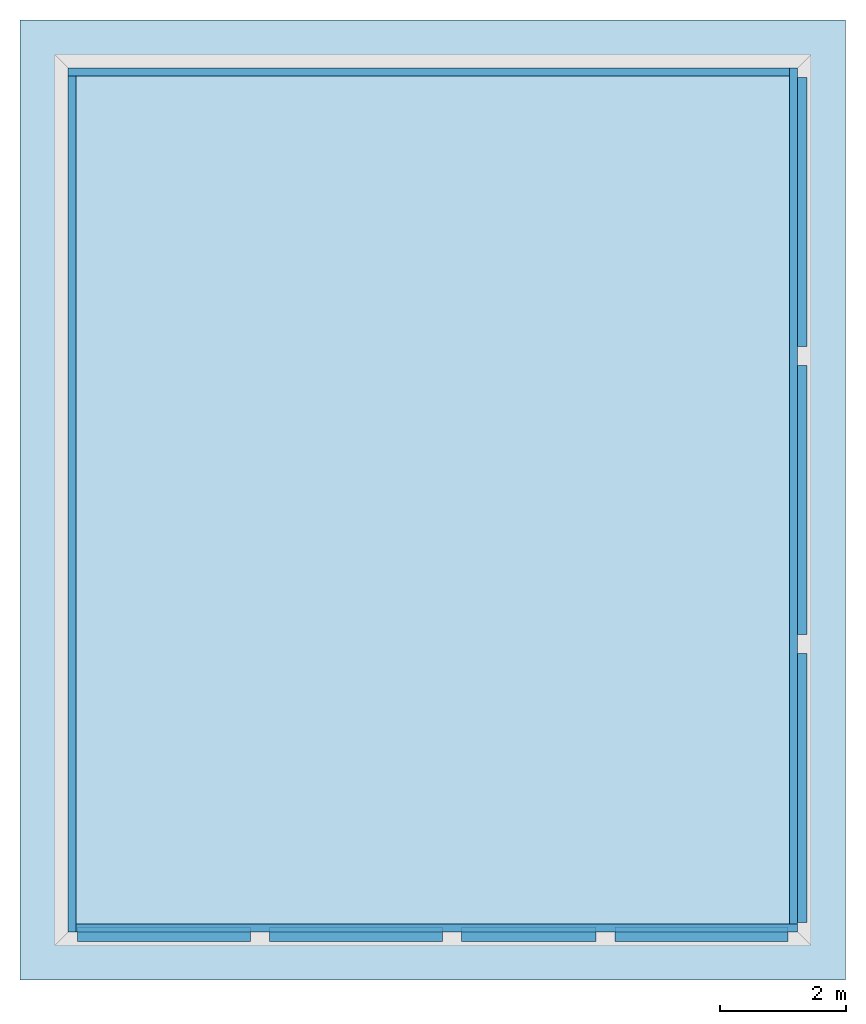
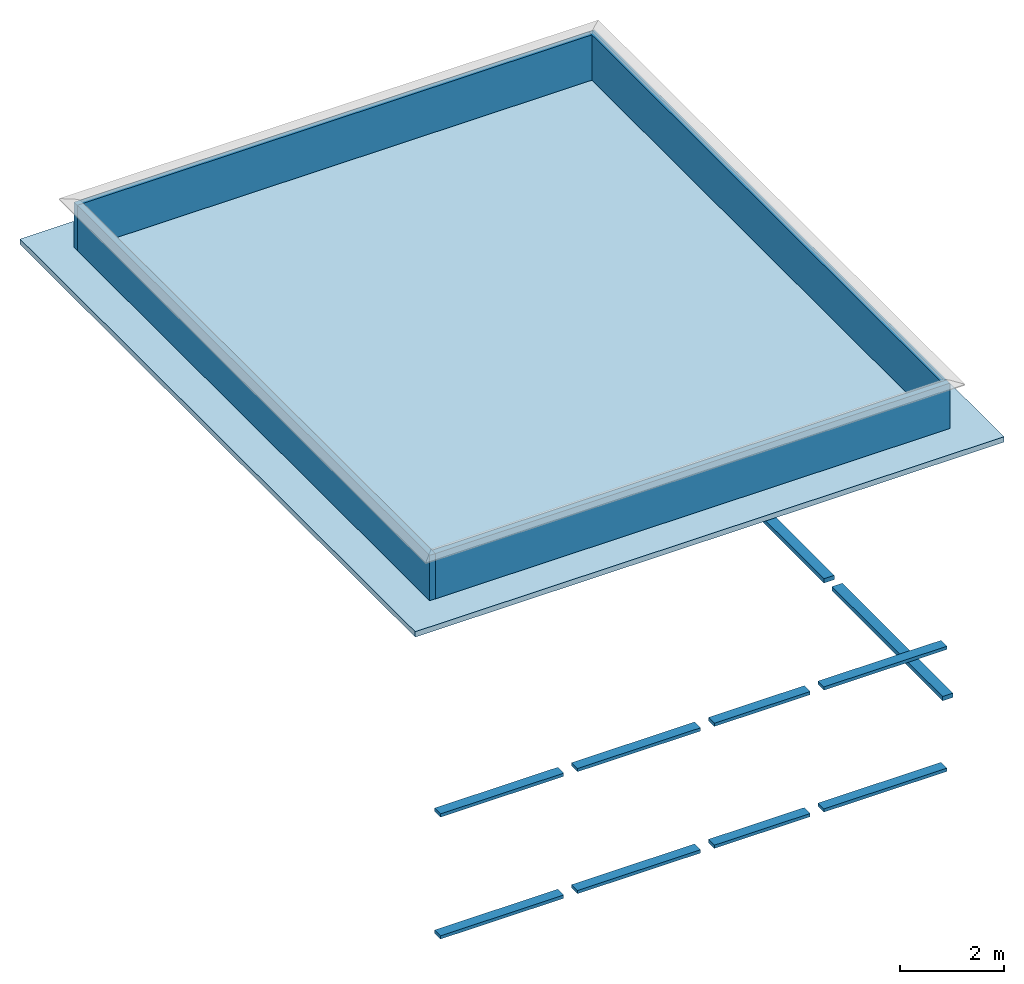
# One storey, part 1 of 2: 4 walls, 3 beams, 1 slab.
"""IFC2X3 building model written with IfcOpenShell, lengths in feet."""

from ifc_helpers import new_model, entity, si_unit, converted_unit, derived_unit, direction, frame, frame_2d, origin, origin_2d_with_axis, place, context, subcontext, project, spatial, rectangle, extrude, source, transform, mapped, material, layer, layer_set, layer_usage, type_object, type_shapes, element, save


model = new_model("IFC2X3")

# Units and contexts
model_context = context("Model", 3, precision=0.0001, world=origin(), true_north=direction((6.123031769111886e-17, 1.0)))
body_context = subcontext(model_context, "Body", "Model", "MODEL_VIEW")
ifc_project = project(units=[converted_unit("LENGTHUNIT", "FOOT", entity("IfcLengthMeasure", 0.3048), si_unit("LENGTHUNIT", "METRE"), dimensions=[1, 0, 0, 0, 0, 0, 0]), converted_unit("AREAUNIT", "SQUARE FOOT", entity("IfcAreaMeasure", 0.09290304), si_unit("AREAUNIT", "SQUARE_METRE"), dimensions=[2, 0, 0, 0, 0, 0, 0]), converted_unit("VOLUMEUNIT", "CUBIC FOOT", entity("IfcVolumeMeasure", 0.028316846592000004), si_unit("VOLUMEUNIT", "CUBIC_METRE"), dimensions=[3, 0, 0, 0, 0, 0, 0]), converted_unit("PLANEANGLEUNIT", "DEGREE", entity("IfcPlaneAngleMeasure", 0.017453292519943278), si_unit("PLANEANGLEUNIT", "RADIAN"), dimensions=[0, 0, 0, 0, 0, 0, 0]), si_unit("MASSUNIT", "GRAM", prefix="KILO"), derived_unit("MASSDENSITYUNIT", [(si_unit("MASSUNIT", "GRAM", prefix="KILO"), 1), (si_unit("LENGTHUNIT", "METRE"), -3)]), derived_unit("IONCONCENTRATIONUNIT", [(si_unit("MASSUNIT", "GRAM", prefix="KILO"), 1), (si_unit("LENGTHUNIT", "METRE"), -3)]), derived_unit("MOMENTOFINERTIAUNIT", [(si_unit("LENGTHUNIT", "METRE"), 4)]), si_unit("TIMEUNIT", "SECOND"), si_unit("FREQUENCYUNIT", "HERTZ"), si_unit("THERMODYNAMICTEMPERATUREUNIT", "DEGREE_CELSIUS"), derived_unit("THERMALTRANSMITTANCEUNIT", [(si_unit("MASSUNIT", "GRAM", prefix="KILO"), 1), (si_unit("THERMODYNAMICTEMPERATUREUNIT", "KELVIN"), -1), (si_unit("TIMEUNIT", "SECOND"), -3)]), derived_unit("THERMALCONDUCTANCEUNIT", [(si_unit("MASSUNIT", "GRAM", prefix="KILO"), 1), (si_unit("THERMODYNAMICTEMPERATUREUNIT", "KELVIN"), -1), (si_unit("TIMEUNIT", "SECOND"), -3), (si_unit("LENGTHUNIT", "METRE"), 1)]), derived_unit("VOLUMETRICFLOWRATEUNIT", [(si_unit("LENGTHUNIT", "METRE"), 3), (si_unit("TIMEUNIT", "SECOND"), -1)]), derived_unit("MASSFLOWRATEUNIT", [(si_unit("MASSUNIT", "GRAM", prefix="KILO"), 1), (si_unit("TIMEUNIT", "SECOND"), -1)]), derived_unit("ROTATIONALFREQUENCYUNIT", [(si_unit("TIMEUNIT", "SECOND"), -1)]), si_unit("ELECTRICCURRENTUNIT", "AMPERE"), si_unit("ELECTRICVOLTAGEUNIT", "VOLT"), si_unit("POWERUNIT", "WATT"), converted_unit("FORCEUNIT", "KIP", entity("IfcForceMeasure", 2.088543423315013e-05), si_unit("FORCEUNIT", "NEWTON"), dimensions=[1, 1, -2, 0, 0, 0, 0]), si_unit("ILLUMINANCEUNIT", "LUX"), si_unit("LUMINOUSFLUXUNIT", "LUMEN"), si_unit("LUMINOUSINTENSITYUNIT", "CANDELA"), si_unit("ENERGYUNIT", "JOULE"), derived_unit("USERDEFINED", [(si_unit("MASSUNIT", "GRAM", prefix="KILO"), -1), (si_unit("LENGTHUNIT", "METRE"), -2), (si_unit("TIMEUNIT", "SECOND"), 3), (si_unit("LUMINOUSFLUXUNIT", "LUMEN"), 1)]), derived_unit("USERDEFINED", [(si_unit("MASSUNIT", "GRAM", prefix="KILO"), 1), (si_unit("TIMEUNIT", "SECOND"), -3), (si_unit("LENGTHUNIT", "METRE"), 3), (si_unit("ELECTRICCURRENTUNIT", "AMPERE"), -2)]), derived_unit("SOUNDPOWERUNIT", [(si_unit("MASSUNIT", "GRAM", prefix="KILO"), 1), (si_unit("TIMEUNIT", "SECOND"), -3), (si_unit("LENGTHUNIT", "METRE"), 2)]), derived_unit("SOUNDPRESSUREUNIT", [(si_unit("MASSUNIT", "GRAM", prefix="KILO"), 1), (si_unit("LENGTHUNIT", "METRE"), -1), (si_unit("TIMEUNIT", "SECOND"), -2)]), derived_unit("LINEARVELOCITYUNIT", [(si_unit("LENGTHUNIT", "METRE"), 1), (si_unit("TIMEUNIT", "SECOND"), -1)]), si_unit("PRESSUREUNIT", "PASCAL"), derived_unit("USERDEFINED", [(si_unit("MASSUNIT", "GRAM", prefix="KILO"), 1), (si_unit("LENGTHUNIT", "METRE"), -2), (si_unit("TIMEUNIT", "SECOND"), -2)]), derived_unit("LINEARFORCEUNIT", [(si_unit("MASSUNIT", "GRAM", prefix="KILO"), 1), (si_unit("TIMEUNIT", "SECOND"), -2)]), derived_unit("PLANARFORCEUNIT", [(si_unit("MASSUNIT", "GRAM", prefix="KILO"), 1), (si_unit("LENGTHUNIT", "METRE"), -1), (si_unit("TIMEUNIT", "SECOND"), -2)]), derived_unit("SPECIFICHEATCAPACITYUNIT", [(si_unit("THERMODYNAMICTEMPERATUREUNIT", "KELVIN"), -1), (si_unit("LENGTHUNIT", "METRE"), 2), (si_unit("TIMEUNIT", "SECOND"), -2)]), derived_unit("HEATFLUXDENSITYUNIT", [(si_unit("MASSUNIT", "GRAM", prefix="KILO"), 1), (si_unit("TIMEUNIT", "SECOND"), -3)]), derived_unit("HEATINGVALUEUNIT", [(si_unit("LENGTHUNIT", "METRE"), 2), (si_unit("TIMEUNIT", "SECOND"), -2)]), derived_unit("VAPORPERMEABILITYUNIT", [(si_unit("LENGTHUNIT", "METRE"), -1), (si_unit("TIMEUNIT", "SECOND"), 1)]), derived_unit("DYNAMICVISCOSITYUNIT", [(si_unit("MASSUNIT", "GRAM", prefix="KILO"), 1), (si_unit("TIMEUNIT", "SECOND"), -1), (si_unit("LENGTHUNIT", "METRE"), -1)]), derived_unit("THERMALEXPANSIONCOEFFICIENTUNIT", [(si_unit("THERMODYNAMICTEMPERATUREUNIT", "KELVIN"), -1)]), derived_unit("MODULUSOFELASTICITYUNIT", [(si_unit("MASSUNIT", "GRAM", prefix="KILO"), 1), (si_unit("LENGTHUNIT", "METRE"), -1), (si_unit("TIMEUNIT", "SECOND"), -2)]), derived_unit("ISOTHERMALMOISTURECAPACITYUNIT", [(si_unit("LENGTHUNIT", "METRE"), 3), (si_unit("MASSUNIT", "GRAM", prefix="KILO"), -1)]), derived_unit("MOISTUREDIFFUSIVITYUNIT", [(si_unit("TIMEUNIT", "SECOND"), -1), (si_unit("LENGTHUNIT", "METRE"), 2)]), derived_unit("MASSPERLENGTHUNIT", [(si_unit("MASSUNIT", "GRAM", prefix="KILO"), 1), (si_unit("LENGTHUNIT", "METRE"), -1)]), derived_unit("THERMALRESISTANCEUNIT", [(si_unit("MASSUNIT", "GRAM", prefix="KILO"), -1), (si_unit("TIMEUNIT", "SECOND"), 3), (si_unit("THERMODYNAMICTEMPERATUREUNIT", "KELVIN"), 1)]), derived_unit("ACCELERATIONUNIT", [(si_unit("LENGTHUNIT", "METRE"), 1), (si_unit("TIMEUNIT", "SECOND"), -2)]), derived_unit("ANGULARVELOCITYUNIT", [(si_unit("TIMEUNIT", "SECOND"), -1), (si_unit("PLANEANGLEUNIT", "RADIAN"), 1)]), derived_unit("LINEARSTIFFNESSUNIT", [(si_unit("MASSUNIT", "GRAM", prefix="KILO"), 1), (si_unit("TIMEUNIT", "SECOND"), -2)]), derived_unit("WARPINGCONSTANTUNIT", [(si_unit("LENGTHUNIT", "METRE"), 6)]), derived_unit("LINEARMOMENTUNIT", [(si_unit("MASSUNIT", "GRAM", prefix="KILO"), 1), (si_unit("LENGTHUNIT", "METRE"), 1), (si_unit("TIMEUNIT", "SECOND"), -2)]), derived_unit("TORQUEUNIT", [(si_unit("MASSUNIT", "GRAM", prefix="KILO"), 1), (si_unit("LENGTHUNIT", "METRE"), 2), (si_unit("TIMEUNIT", "SECOND"), -2)])], contexts=[model_context])

# Site, building, storey
site_placement = place(None, origin())
site = spatial("IfcSite", under=ifc_project, at=site_placement, CompositionType="ELEMENT")
building_placement = place(site_placement, origin())
building = spatial("IfcBuilding", under=site, at=building_placement, CompositionType="ELEMENT")
storey_placement = place(building_placement, frame((0.0, 0.0, 28.25000000000186)))
storey = spatial("IfcBuildingStorey", under=building, at=storey_placement, Name="Third Floor", CompositionType="ELEMENT", Elevation=28.25000000000186)

# Beams
ifc_material_1 = material(Name="Concrete, Cast-in-Place gray")
beam_type_1 = type_object("IfcBeamType", PredefinedType="BEAM", material=ifc_material_1)
shared_shape_1 = source(origin(), body_context, "Body", "SweptSolid", [
    extrude(rectangle(XDim=0.33333333333333304, YDim=0.7500000000000142, at=frame_2d((-7.105427357601002e-15, -4.440892098500626e-16), x_axis=(0.0, 1.0))), frame((47.999478019162154, -19.341244847249058, 7.166666666666661), z_axis=(0.0, 1.0, 0.0), x_axis=(-1.0, 0.0, 0.0)), (0.0, 0.0, 1.0), 14.000000000000057),
    extrude(rectangle(XDim=0.33333333333333304, YDim=0.7500000000000142, at=frame_2d((-7.105427357601002e-15, -4.440892098500626e-16), x_axis=(0.0, 1.0))), frame((47.999478019162154, -49.34124484724906, 7.166666666666661), z_axis=(0.0, 1.0, 0.0), x_axis=(-1.0, 0.0, 0.0)), (0.0, 0.0, 1.0), 14.0),
    extrude(rectangle(XDim=0.33333333333333304, YDim=0.7500000000000142, at=frame_2d((-7.105427357601002e-15, -4.440892098500626e-16), x_axis=(0.0, 1.0))), frame((47.999478019162154, -34.34124484724906, 7.166666666666661), z_axis=(0.0, 1.0, 0.0), x_axis=(-1.0, 0.0, 0.0)), (0.0, 0.0, 1.0), 14.000000000000004),
])
type_shapes(beam_type_1, [shared_shape_1])
beam_1_placement = place(storey_placement, frame((0.0, 0.0, -28.25000000000186)))
element("IfcBeam", 1, at=beam_1_placement, inside=storey, type_object=beam_type_1, material=ifc_material_1, context=body_context, shape_type="MappedRepresentation", body=[
    mapped(shared_shape_1, transform((0.0, 0.0, 0.0), scale=1.0)),
])
beam_type_2 = type_object("IfcBeamType", PredefinedType="BEAM", material=ifc_material_1)
shared_shape_2 = source(origin(), body_context, "Body", "SweptSolid", [
    extrude(rectangle(XDim=0.24999999999999956, YDim=0.7500000000000142, at=frame_2d((2.220446049250313e-16, 0.0), x_axis=(1.0, 0.0))), frame((38.37447801916216, -49.96624484724887, 2.3749999999999947), z_axis=(1.0, 0.0, 0.0), x_axis=(0.0, 0.0, -1.0)), (0.0, 0.0, 1.0), 9.000000000000007),
    extrude(rectangle(XDim=0.24999999999999956, YDim=0.7500000000000142, at=frame_2d((2.220446049250313e-16, 0.0), x_axis=(1.0, 0.0))), frame((10.37447801916216, -49.96624484724887, 2.3749999999999947), z_axis=(1.0, 0.0, 0.0), x_axis=(0.0, 0.0, -1.0)), (0.0, 0.0, 1.0), 8.999999999999998),
    extrude(rectangle(XDim=0.24999999999999956, YDim=0.7500000000000142, at=frame_2d((2.220446049250313e-16, 0.0), x_axis=(1.0, 0.0))), frame((30.374478019162154, -49.96624484724887, 2.3749999999999947), z_axis=(1.0, 0.0, 0.0), x_axis=(0.0, 0.0, -1.0)), (0.0, 0.0, 1.0), 7.000000000000007),
    extrude(rectangle(XDim=0.24999999999999956, YDim=0.7500000000000142, at=frame_2d((2.220446049250313e-16, 0.0), x_axis=(1.0, 0.0))), frame((20.374478019162158, -49.96624484724887, 2.3749999999999947), z_axis=(1.0, 0.0, 0.0), x_axis=(0.0, 0.0, -1.0)), (0.0, 0.0, 1.0), 8.999999999999996),
])
type_shapes(beam_type_2, [shared_shape_2])
beam_2_placement = place(storey_placement, frame((0.0, 0.0, -28.25000000000186)))
element("IfcBeam", 2, at=beam_2_placement, inside=storey, type_object=beam_type_2, material=ifc_material_1, context=body_context, shape_type="MappedRepresentation", body=[
    mapped(shared_shape_2, transform((0.0, 0.0, 0.0), scale=1.0)),
])
beam_type_3 = type_object("IfcBeamType", PredefinedType="BEAM", material=ifc_material_1)
shared_shape_3 = source(origin(), body_context, "Body", "SweptSolid", [
    extrude(rectangle(XDim=0.25, YDim=0.7500000000000142, at=frame_2d((0.0, -3.552713678800501e-15), x_axis=(1.0, 0.0))), frame((38.374478019162154, -49.966244847249015, 11.79166666666839), z_axis=(1.0, 0.0, 0.0), x_axis=(0.0, 0.0, -1.0)), (0.0, 0.0, 1.0), 9.00000000000001),
    extrude(rectangle(XDim=0.25, YDim=0.7500000000000142, at=frame_2d((0.0, -1.4210854715202004e-14), x_axis=(1.0, 0.0))), frame((10.374478019162162, -49.966244847248916, 11.79166666666839), z_axis=(1.0, 0.0, 0.0), x_axis=(0.0, 0.0, -1.0)), (0.0, 0.0, 1.0), 9.0),
    extrude(rectangle(XDim=0.25, YDim=0.7500000000000142, at=origin_2d_with_axis()), frame((30.374478019162154, -49.966244847248994, 11.79166666666839), z_axis=(1.0, 0.0, 0.0), x_axis=(0.0, 0.0, -1.0)), (0.0, 0.0, 1.0), 7.0000000000000036),
    extrude(rectangle(XDim=0.25, YDim=0.7500000000000142, at=origin_2d_with_axis()), frame((20.374478019162154, -49.966244847248966, 11.79166666666839), z_axis=(1.0, 0.0, 0.0), x_axis=(0.0, 0.0, -1.0)), (0.0, 0.0, 1.0), 8.999999999999996),
])
type_shapes(beam_type_3, [shared_shape_3])
beam_3_placement = place(storey_placement, frame((0.0, 0.0, -28.25000000000186)))
element("IfcBeam", 3, at=beam_3_placement, inside=storey, type_object=beam_type_3, material=ifc_material_1, context=body_context, shape_type="MappedRepresentation", body=[
    mapped(shared_shape_3, transform((0.0, 0.0, 0.0), scale=1.0)),
])

# Slab
ifc_material_2 = material(Name="Default Floor")
ifc_layer_1 = layer(ifc_material_2, 0.4166666666666667)
ifc_layer_set_1 = layer_set([ifc_layer_1])
ifc_layer_usage_1 = layer_usage(ifc_layer_set_1, "AXIS3", "POSITIVE", 0.0)
slab_type = type_object("IfcSlabType", PredefinedType="FLOOR", material=ifc_layer_set_1)
slab_placement = place(storey_placement, origin())
element("IfcSlab", 4, at=slab_placement, inside=storey, type_object=slab_type, material=ifc_layer_usage_1, PredefinedType="FLOOR", context=body_context, shape_type="SweptSolid", body=[
    extrude(rectangle(XDim=50.00000000000018, YDim=42.99999999999993, at=origin_2d_with_axis()), frame((28.874478019162204, -27.34124484724897, 0.0), z_axis=(0.0, 0.0, -1.0), x_axis=(0.0, 1.0, 0.0)), (0.0, 0.0, 1.0), 0.41666666666666785),
])

# Walls
ifc_material_3 = material(Name="Default Wall")
ifc_layer_2 = layer(ifc_material_3, 0.4166666666666667)
ifc_layer_set_2 = layer_set([ifc_layer_2], Name="Basic Wall:Parapet Wall")
ifc_layer_usage_2 = layer_usage(ifc_layer_set_2, "AXIS2", "NEGATIVE", 0.20833333333333334)
wall_type = type_object("IfcWallType", Name="Basic Wall:Parapet Wall", PredefinedType="STANDARD", material=ifc_layer_set_2)
wall_1_placement = place(storey_placement, frame((9.874478019163185, -5.049578180582901, 0.0)))
element("IfcWallStandardCase", 5, at=wall_1_placement, inside=storey, type_object=wall_type, material=ifc_layer_usage_2, Name="Basic Wall:Parapet Wall", ObjectType="Basic Wall:Parapet Wall", context=body_context, shape_type="SweptSolid", body=[
    extrude(rectangle(XDim=37.583333333333485, YDim=0.4166666666666661, at=frame_2d((18.791666666666742, 0.0), x_axis=(-1.0, 0.0))), origin(), (0.0, 0.0, 1.0), 3.5),
])
wall_2_placement = place(storey_placement, frame((10.08281135249652, -49.84124484724977, 0.0), z_axis=(0.0, 0.0, 1.0), x_axis=(0.0, 1.0, 0.0)))
element("IfcWallStandardCase", 6, at=wall_2_placement, inside=storey, type_object=wall_type, material=ifc_layer_usage_2, Name="Basic Wall:Parapet Wall", ObjectType="Basic Wall:Parapet Wall", context=body_context, shape_type="SweptSolid", body=[
    extrude(rectangle(XDim=44.583333333333535, YDim=0.41666666666666785, at=frame_2d((22.291666666666767, 0.0), x_axis=(-1.0, 0.0))), origin(), (0.0, 0.0, 1.0), 3.5),
])
wall_3_placement = place(storey_placement, frame((47.87447801916333, -49.63291151391643, 0.0), z_axis=(0.0, 0.0, 1.0), x_axis=(-1.0, 0.0, 0.0)))
element("IfcWallStandardCase", 7, at=wall_3_placement, inside=storey, type_object=wall_type, material=ifc_layer_usage_2, Name="Basic Wall:Parapet Wall", ObjectType="Basic Wall:Parapet Wall", context=body_context, shape_type="SweptSolid", body=[
    extrude(rectangle(XDim=37.58333333333347, YDim=0.4166666666666714, at=frame_2d((18.791666666666735, 0.0), x_axis=(-1.0, 0.0))), origin(), (0.0, 0.0, 1.0), 3.5),
])
wall_4_placement = place(storey_placement, frame((47.66614468583, -4.841244847249568, 0.0), z_axis=(0.0, 0.0, 1.0), x_axis=(0.0, -1.0, 0.0)))
element("IfcWallStandardCase", 8, at=wall_4_placement, inside=storey, type_object=wall_type, material=ifc_layer_usage_2, Name="Basic Wall:Parapet Wall", ObjectType="Basic Wall:Parapet Wall", context=body_context, shape_type="SweptSolid", body=[
    extrude(rectangle(XDim=44.583333333333535, YDim=0.4166666666666714, at=frame_2d((22.291666666666767, -5.551115123125783e-17), x_axis=(-1.0, 0.0))), origin(), (0.0, 0.0, 1.0), 3.5),
])

save(model, "model.ifc")
